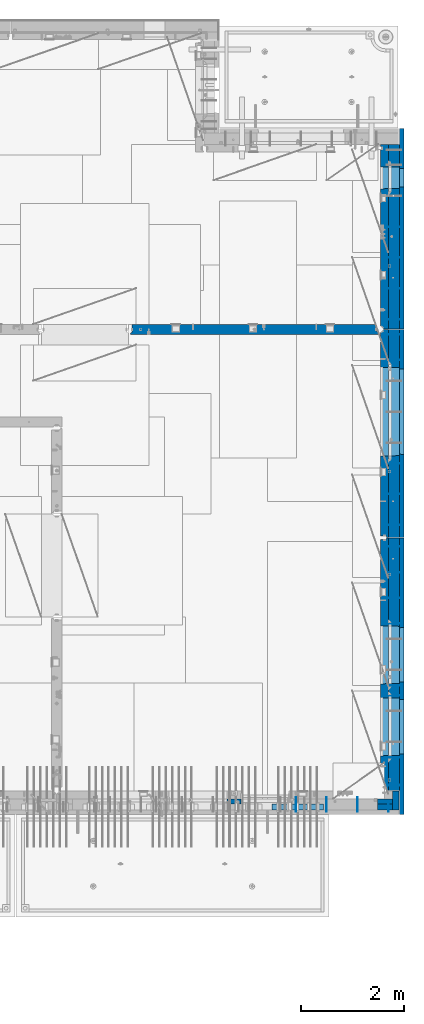
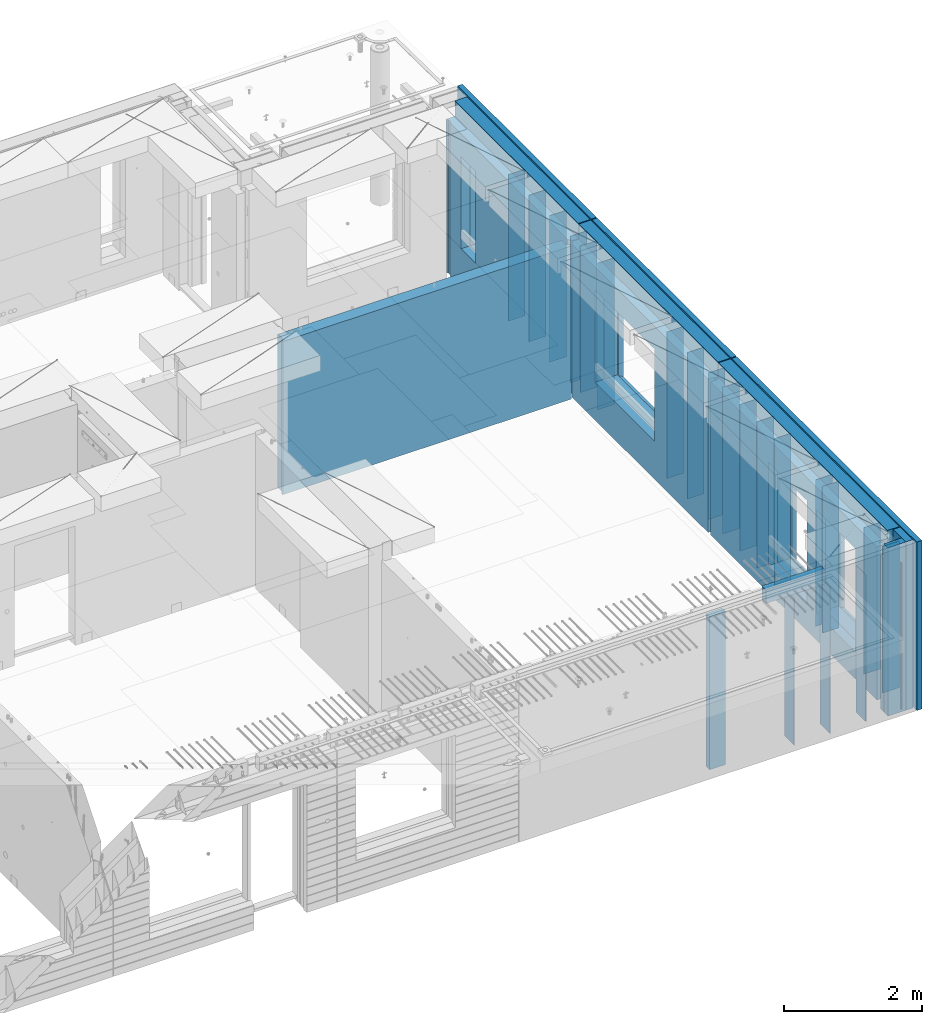
# One storey, part 230 of 334: 37 walls, 7 elements without a shape of their own.
"""IFC2X3 building model written with IfcOpenShell, lengths in millimetres."""

from ifc_helpers import new_model, si_unit, frame, origin_with_axes, place, context, subcontext, project, spatial, faceted_brep, material, type_object, element, aggregate, save


model = new_model("IFC2X3")

# Units and contexts
model_context = context("Model", 3, precision=1e-05, world=origin_with_axes())
body_context = subcontext(model_context, "Body", "Model", "MODEL_VIEW")
ifc_project = project(units=[si_unit("LENGTHUNIT", "METRE", prefix="MILLI"), si_unit("AREAUNIT", "SQUARE_METRE"), si_unit("VOLUMEUNIT", "CUBIC_METRE"), si_unit("MASSUNIT", "GRAM", prefix="KILO"), si_unit("TIMEUNIT", "SECOND"), si_unit("PLANEANGLEUNIT", "RADIAN"), si_unit("SOLIDANGLEUNIT", "STERADIAN"), si_unit("THERMODYNAMICTEMPERATUREUNIT", "DEGREE_CELSIUS"), si_unit("LUMINOUSINTENSITYUNIT", "LUMEN")], contexts=[model_context])

# Site, building, storey
site_placement = place(None, origin_with_axes())
site = spatial("IfcSite", under=ifc_project, at=site_placement, CompositionType="ELEMENT")
building_placement = place(site_placement, origin_with_axes())
building = spatial("IfcBuilding", under=site, at=building_placement, CompositionType="ELEMENT")
storey_placement = place(building_placement, origin_with_axes())
storey = spatial("IfcBuildingStorey", under=building, at=storey_placement, Name="3", CompositionType="ELEMENT", Elevation=0.0)

# Assembly, walls
assembly_1_placement = place(storey_placement, origin_with_axes())
assembly_1 = element("IfcElementAssembly", 1, at=assembly_1_placement, inside=storey, AssemblyPlace="NOTDEFINED", PredefinedType="REINFORCEMENT_UNIT")
ifc_material_1 = material(Name="Undefined")
wall_type_1 = type_object("IfcWallType", PredefinedType="NOTDEFINED")
wall_1_placement = place(assembly_1_placement, frame((35060.0, 7780.0, 89115.0), z_axis=(0.0, 0.0, 1.0), x_axis=(0.0, -1.0, 0.0)))
wall_1 = element("IfcWall", 2, at=wall_1_placement, type_object=wall_type_1, material=ifc_material_1, Name="(PD)", context=body_context, shape_type="Brep", body=[
    faceted_brep([(0.0, 5.0, -1300.0), (0.0, 5.0, 1300.0), (180.0, 5.0, 1300.0), (180.0, 5.0, -1300.0), (0.0, -5.0, 1300.0), (180.0, -5.0, 1300.0), (0.0, -5.0, -1300.0), (180.0, -5.0, -1300.0)], [[[0, 1, 2, 3]], [[1, 4, 5, 2]], [[4, 6, 7, 5]], [[6, 0, 3, 7]], [[5, 7, 3, 2]], [[6, 4, 1, 0]]]),
])
wall_2_placement = place(assembly_1_placement, frame((34460.0, 7880.0, 89115.0), z_axis=(0.0, 0.0, 1.0), x_axis=(0.0, -1.0, 0.0)))
wall_2 = element("IfcWall", 3, at=wall_2_placement, type_object=wall_type_1, material=ifc_material_1, Name="(PD)", context=body_context, shape_type="Brep", body=[
    faceted_brep([(0.0, 5.0, -1300.0), (0.0, 5.0, 1300.0), (280.0, 5.0, 1300.0), (280.0, 5.0, -1300.0), (0.0, -5.0, 1300.0), (280.0, -5.0, 1300.0), (0.0, -5.0, -1300.0), (280.0, -5.0, -1300.0)], [[[0, 1, 2, 3]], [[1, 4, 5, 2]], [[4, 6, 7, 5]], [[6, 0, 3, 7]], [[5, 7, 3, 2]], [[6, 4, 1, 0]]]),
])
wall_3_placement = place(assembly_1_placement, frame((33860.0, 7880.0, 89115.0), z_axis=(0.0, 0.0, 1.0), x_axis=(0.0, -1.0, 0.0)))
wall_3 = element("IfcWall", 4, at=wall_3_placement, type_object=wall_type_1, material=ifc_material_1, Name="(PD)", context=body_context, shape_type="Brep", body=[
    faceted_brep([(0.0, 5.0, -1300.0), (0.0, 5.0, 1300.0), (280.0, 5.0, 1300.0), (280.0, 5.0, -1300.0), (0.0, -5.0, 1300.0), (280.0, -5.0, 1300.0), (0.0, -5.0, -1300.0), (280.0, -5.0, -1300.0)], [[[0, 1, 2, 3]], [[1, 4, 5, 2]], [[4, 6, 7, 5]], [[6, 0, 3, 7]], [[5, 7, 3, 2]], [[6, 4, 1, 0]]]),
])

assembly_2_placement = place(storey_placement, origin_with_axes())
assembly_2 = element("IfcElementAssembly", 5, at=assembly_2_placement, inside=storey, AssemblyPlace="NOTDEFINED", PredefinedType="REINFORCEMENT_UNIT")
wall_4_placement = place(assembly_2_placement, frame((35030.0, 12755.0002861023, 89115.0), z_axis=(0.0, 0.0, 1.0), x_axis=(1.0, 0.0, 0.0)))
wall_4 = element("IfcWall", 6, at=wall_4_placement, type_object=wall_type_1, material=ifc_material_1, Name="(PD)", context=body_context, shape_type="Brep", body=[
    faceted_brep([(0.0, 5.0, -1300.0), (0.0, 5.0, 1300.0), (280.0, 5.0, 1300.0), (280.0, 5.0, -1300.0), (0.0, -5.0, 1300.0), (280.0, -5.0, 1300.0), (0.0, -5.0, -1300.0), (280.0, -5.0, -1300.0)], [[[0, 1, 2, 3]], [[1, 4, 5, 2]], [[4, 6, 7, 5]], [[6, 0, 3, 7]], [[5, 7, 3, 2]], [[6, 4, 1, 0]]]),
])
wall_5_placement = place(assembly_2_placement, frame((35030.0, 12255.0002861023, 89115.0), z_axis=(0.0, 0.0, 1.0), x_axis=(1.0, 0.0, 0.0)))
wall_5 = element("IfcWall", 7, at=wall_5_placement, type_object=wall_type_1, material=ifc_material_1, Name="(PD)", context=body_context, shape_type="Brep", body=[
    faceted_brep([(0.0, 5.0, -1300.0), (0.0, 5.0, 1300.0), (280.0, 5.0, 1300.0), (280.0, 5.0, -1300.0), (0.0, -5.0, 1300.0), (280.0, -5.0, 1300.0), (0.0, -5.0, -1300.0), (280.0, -5.0, -1300.0)], [[[0, 1, 2, 3]], [[1, 4, 5, 2]], [[4, 6, 7, 5]], [[6, 0, 3, 7]], [[5, 7, 3, 2]], [[6, 4, 1, 0]]]),
])
wall_6_placement = place(assembly_2_placement, frame((35030.0, 11755.0002861023, 89115.0), z_axis=(0.0, 0.0, 1.0), x_axis=(1.0, 0.0, 0.0)))
wall_6 = element("IfcWall", 8, at=wall_6_placement, type_object=wall_type_1, material=ifc_material_1, Name="(PD)", context=body_context, shape_type="Brep", body=[
    faceted_brep([(0.0, 5.0, -1300.0), (0.0, 5.0, 1300.0), (280.0, 5.0, 1300.0), (280.0, 5.0, -1300.0), (0.0, -5.0, 1300.0), (280.0, -5.0, 1300.0), (0.0, -5.0, -1300.0), (280.0, -5.0, -1300.0)], [[[0, 1, 2, 3]], [[1, 4, 5, 2]], [[4, 6, 7, 5]], [[6, 0, 3, 7]], [[5, 7, 3, 2]], [[6, 4, 1, 0]]]),
])
wall_7_placement = place(assembly_2_placement, frame((35030.0, 11255.0002861023, 89115.0), z_axis=(0.0, 0.0, 1.0), x_axis=(1.0, 0.0, 0.0)))
wall_7 = element("IfcWall", 9, at=wall_7_placement, type_object=wall_type_1, material=ifc_material_1, Name="(PD)", context=body_context, shape_type="Brep", body=[
    faceted_brep([(0.0, 5.0, -1300.0), (0.0, 5.0, 1300.0), (280.0, 5.0, 1300.0), (280.0, 5.0, -1300.0), (0.0, -5.0, 1300.0), (280.0, -5.0, 1300.0), (0.0, -5.0, -1300.0), (280.0, -5.0, -1300.0)], [[[0, 1, 2, 3]], [[1, 4, 5, 2]], [[4, 6, 7, 5]], [[6, 0, 3, 7]], [[5, 7, 3, 2]], [[6, 4, 1, 0]]]),
])
wall_8_placement = place(assembly_2_placement, frame((35030.0, 8105.0, 89115.0), z_axis=(0.0, 0.0, 1.0), x_axis=(1.0, 0.0, 0.0)))
wall_8 = element("IfcWall", 10, at=wall_8_placement, type_object=wall_type_1, material=ifc_material_1, Name="(PD)", context=body_context, shape_type="Brep", body=[
    faceted_brep([(0.0, 5.0, -1300.0), (0.0, 5.0, 1300.0), (280.0, 5.0, 1300.0), (280.0, 5.0, -1300.0), (0.0, -5.0, 1300.0), (280.0, -5.0, 1300.0), (0.0, -5.0, -1300.0), (280.0, -5.0, -1300.0)], [[[0, 1, 2, 3]], [[1, 4, 5, 2]], [[4, 6, 7, 5]], [[6, 0, 3, 7]], [[5, 7, 3, 2]], [[6, 4, 1, 0]]]),
])
wall_9_placement = place(assembly_2_placement, frame((35030.0, 8115.0, 89115.0), z_axis=(0.0, 0.0, 1.0), x_axis=(1.0, 0.0, 0.0)))
wall_9 = element("IfcWall", 11, at=wall_9_placement, type_object=wall_type_1, material=ifc_material_1, Name="(PD)", context=body_context, shape_type="Brep", body=[
    faceted_brep([(0.0, 5.0, -1300.0), (0.0, 5.0, 1300.0), (280.0, 5.0, 1300.0), (280.0, 5.0, -1300.0), (0.0, -5.0, 1300.0), (280.0, -5.0, 1300.0), (0.0, -5.0, -1300.0), (280.0, -5.0, -1300.0)], [[[0, 1, 2, 3]], [[1, 4, 5, 2]], [[4, 6, 7, 5]], [[6, 0, 3, 7]], [[5, 7, 3, 2]], [[6, 4, 1, 0]]]),
])
wall_10_placement = place(assembly_2_placement, frame((35030.0, 9855.00028610229, 89115.0), z_axis=(0.0, 0.0, 1.0), x_axis=(1.0, 0.0, 0.0)))
wall_10 = element("IfcWall", 12, at=wall_10_placement, type_object=wall_type_1, material=ifc_material_1, Name="(PD)", context=body_context, shape_type="Brep", body=[
    faceted_brep([(0.0, 5.0, -1300.0), (0.0, 5.0, 1300.0), (280.0, 5.0, 1300.0), (280.0, 5.0, -1300.0), (0.0, -5.0, 1300.0), (280.0, -5.0, 1300.0), (0.0, -5.0, -1300.0), (280.0, -5.0, -1300.0)], [[[0, 1, 2, 3]], [[1, 4, 5, 2]], [[4, 6, 7, 5]], [[6, 0, 3, 7]], [[5, 7, 3, 2]], [[6, 4, 1, 0]]]),
])
wall_11_placement = place(assembly_2_placement, frame((35030.0, 10055.0002861023, 89115.0), z_axis=(0.0, 0.0, 1.0), x_axis=(1.0, 0.0, 0.0)))
wall_11 = element("IfcWall", 13, at=wall_11_placement, type_object=wall_type_1, material=ifc_material_1, Name="(PD)", context=body_context, shape_type="Brep", body=[
    faceted_brep([(0.0, 5.0, -1300.0), (0.0, 5.0, 1300.0), (280.0, 5.0, 1300.0), (280.0, 5.0, -1300.0), (0.0, -5.0, 1300.0), (280.0, -5.0, 1300.0), (0.0, -5.0, -1300.0), (280.0, -5.0, -1300.0)], [[[0, 1, 2, 3]], [[1, 4, 5, 2]], [[4, 6, 7, 5]], [[6, 0, 3, 7]], [[5, 7, 3, 2]], [[6, 4, 1, 0]]]),
])

assembly_3_placement = place(storey_placement, origin_with_axes())
assembly_3 = element("IfcElementAssembly", 14, at=assembly_3_placement, inside=storey, AssemblyPlace="NOTDEFINED", PredefinedType="REINFORCEMENT_UNIT")
wall_12_placement = place(assembly_3_placement, frame((35030.0, 13175.0002861023, 89115.0), z_axis=(0.0, 0.0, 1.0), x_axis=(1.0, 0.0, 0.0)))
wall_12 = element("IfcWall", 15, at=wall_12_placement, type_object=wall_type_1, material=ifc_material_1, Name="(PD)", context=body_context, shape_type="Brep", body=[
    faceted_brep([(0.0, 5.0, -1300.0), (0.0, 5.0, 1300.0), (280.0, 5.0, 1300.0), (280.0, 5.0, -1300.0), (0.0, -5.0, 1300.0), (280.0, -5.0, 1300.0), (0.0, -5.0, -1300.0), (280.0, -5.0, -1300.0)], [[[0, 1, 2, 3]], [[1, 4, 5, 2]], [[4, 6, 7, 5]], [[6, 0, 3, 7]], [[5, 7, 3, 2]], [[6, 4, 1, 0]]]),
])
wall_13_placement = place(assembly_3_placement, frame((35030.0, 13775.0002861023, 89115.0), z_axis=(0.0, 0.0, 1.0), x_axis=(1.0, 0.0, 0.0)))
wall_13 = element("IfcWall", 16, at=wall_13_placement, type_object=wall_type_1, material=ifc_material_1, Name="(PD)", context=body_context, shape_type="Brep", body=[
    faceted_brep([(0.0, 5.0, -1300.0), (0.0, 5.0, 1300.0), (280.0, 5.0, 1300.0), (280.0, 5.0, -1300.0), (0.0, -5.0, 1300.0), (280.0, -5.0, 1300.0), (0.0, -5.0, -1300.0), (280.0, -5.0, -1300.0)], [[[0, 1, 2, 3]], [[1, 4, 5, 2]], [[4, 6, 7, 5]], [[6, 0, 3, 7]], [[5, 7, 3, 2]], [[6, 4, 1, 0]]]),
])
wall_14_placement = place(assembly_3_placement, frame((35030.0, 16885.0002861023, 89115.0), z_axis=(0.0, 0.0, 1.0), x_axis=(1.0, 0.0, 0.0)))
wall_14 = element("IfcWall", 17, at=wall_14_placement, type_object=wall_type_1, material=ifc_material_1, Name="(PD)", context=body_context, shape_type="Brep", body=[
    faceted_brep([(0.0, 5.0, -1300.0), (0.0, 5.0, 1300.0), (280.0, 5.0, 1300.0), (280.0, 5.0, -1300.0), (0.0, -5.0, 1300.0), (280.0, -5.0, 1300.0), (0.0, -5.0, -1300.0), (280.0, -5.0, -1300.0)], [[[0, 1, 2, 3]], [[1, 4, 5, 2]], [[4, 6, 7, 5]], [[6, 0, 3, 7]], [[5, 7, 3, 2]], [[6, 4, 1, 0]]]),
])
wall_15_placement = place(assembly_3_placement, frame((35030.0, 16385.0002861023, 89115.0), z_axis=(0.0, 0.0, 1.0), x_axis=(1.0, 0.0, 0.0)))
wall_15 = element("IfcWall", 18, at=wall_15_placement, type_object=wall_type_1, material=ifc_material_1, Name="(PD)", context=body_context, shape_type="Brep", body=[
    faceted_brep([(0.0, 5.0, -1300.0), (0.0, 5.0, 1300.0), (280.0, 5.0, 1300.0), (280.0, 5.0, -1300.0), (0.0, -5.0, 1300.0), (280.0, -5.0, 1300.0), (0.0, -5.0, -1300.0), (280.0, -5.0, -1300.0)], [[[0, 1, 2, 3]], [[1, 4, 5, 2]], [[4, 6, 7, 5]], [[6, 0, 3, 7]], [[5, 7, 3, 2]], [[6, 4, 1, 0]]]),
])

assembly_4_placement = place(storey_placement, origin_with_axes())
assembly_4 = element("IfcElementAssembly", 19, at=assembly_4_placement, inside=storey, AssemblyPlace="NOTDEFINED", PredefinedType="REINFORCEMENT_UNIT")
wall_16_placement = place(assembly_4_placement, frame((35030.0, 17175.0002441406, 89115.0), z_axis=(0.0, 0.0, 1.0), x_axis=(1.0, 0.0, 0.0)))
wall_16 = element("IfcWall", 20, at=wall_16_placement, type_object=wall_type_1, material=ifc_material_1, Name="(PD)", context=body_context, shape_type="Brep", body=[
    faceted_brep([(0.0, 5.0, -1300.0), (0.0, 5.0, 1300.0), (280.0, 5.0, 1300.0), (280.0, 5.0, -1300.0), (0.0, -5.0, 1300.0), (280.0, -5.0, 1300.0), (0.0, -5.0, -1300.0), (280.0, -5.0, -1300.0)], [[[0, 1, 2, 3]], [[1, 4, 5, 2]], [[4, 6, 7, 5]], [[6, 0, 3, 7]], [[5, 7, 3, 2]], [[6, 4, 1, 0]]]),
])
wall_17_placement = place(assembly_4_placement, frame((35030.0, 17775.0002441406, 89115.0), z_axis=(0.0, 0.0, 1.0), x_axis=(1.0, 0.0, 0.0)))
wall_17 = element("IfcWall", 21, at=wall_17_placement, type_object=wall_type_1, material=ifc_material_1, Name="(PD)", context=body_context, shape_type="Brep", body=[
    faceted_brep([(0.0, 5.0, -1300.0), (0.0, 5.0, 1300.0), (280.0, 5.0, 1300.0), (280.0, 5.0, -1300.0), (0.0, -5.0, 1300.0), (280.0, -5.0, 1300.0), (0.0, -5.0, -1300.0), (280.0, -5.0, -1300.0)], [[[0, 1, 2, 3]], [[1, 4, 5, 2]], [[4, 6, 7, 5]], [[6, 0, 3, 7]], [[5, 7, 3, 2]], [[6, 4, 1, 0]]]),
])
wall_18_placement = place(assembly_4_placement, frame((35030.0, 18375.0002441406, 89115.0), z_axis=(0.0, 0.0, 1.0), x_axis=(1.0, 0.0, 0.0)))
wall_18 = element("IfcWall", 22, at=wall_18_placement, type_object=wall_type_1, material=ifc_material_1, Name="(PD)", context=body_context, shape_type="Brep", body=[
    faceted_brep([(0.0, 5.0, -1300.0), (0.0, 5.0, 1300.0), (280.0, 5.0, 1300.0), (280.0, 5.0, -1300.0), (0.0, -5.0, 1300.0), (280.0, -5.0, 1300.0), (0.0, -5.0, -1300.0), (280.0, -5.0, -1300.0)], [[[0, 1, 2, 3]], [[1, 4, 5, 2]], [[4, 6, 7, 5]], [[6, 0, 3, 7]], [[5, 7, 3, 2]], [[6, 4, 1, 0]]]),
])
wall_19_placement = place(assembly_4_placement, frame((35030.0, 18975.0002441406, 89115.0), z_axis=(0.0, 0.0, 1.0), x_axis=(1.0, 0.0, 0.0)))
wall_19 = element("IfcWall", 23, at=wall_19_placement, type_object=wall_type_1, material=ifc_material_1, Name="(PD)", context=body_context, shape_type="Brep", body=[
    faceted_brep([(0.0, 5.0, -1300.0), (0.0, 5.0, 1300.0), (280.0, 5.0, 1300.0), (280.0, 5.0, -1300.0), (0.0, -5.0, 1300.0), (280.0, -5.0, 1300.0), (0.0, -5.0, -1300.0), (280.0, -5.0, -1300.0)], [[[0, 1, 2, 3]], [[1, 4, 5, 2]], [[4, 6, 7, 5]], [[6, 0, 3, 7]], [[5, 7, 3, 2]], [[6, 4, 1, 0]]]),
])

# Wall
wall_20_placement = place(assembly_3_placement, frame((35030.0, 14375.0002861023, 89115.0), z_axis=(0.0, 0.0, 1.0), x_axis=(1.0, 0.0, 0.0)))
wall_20 = element("IfcWall", 24, at=wall_20_placement, type_object=wall_type_1, material=ifc_material_1, Name="(PD)", context=body_context, shape_type="Brep", body=[
    faceted_brep([(0.0, 5.0, -1300.0), (0.0, 5.0, 1300.0), (280.0, 5.0, 1300.0), (280.0, 5.0, -1300.0), (0.0, -5.0, 1300.0), (280.0, -5.0, 1300.0), (0.0, -5.0, -1300.0), (280.0, -5.0, -1300.0)], [[[0, 1, 2, 3]], [[1, 4, 5, 2]], [[4, 6, 7, 5]], [[6, 0, 3, 7]], [[5, 7, 3, 2]], [[6, 4, 1, 0]]]),
])

wall_21_placement = place(assembly_1_placement, frame((33260.0, 7880.0, 89115.0), z_axis=(0.0, 0.0, 1.0), x_axis=(0.0, -1.0, 0.0)))
wall_21 = element("IfcWall", 25, at=wall_21_placement, type_object=wall_type_1, material=ifc_material_1, Name="(PD)", context=body_context, shape_type="Brep", body=[
    faceted_brep([(0.0, 5.0, -1300.0), (0.0, 5.0, 1300.0), (280.0, 5.0, 1300.0), (280.0, 5.0, -1300.0), (0.0, -5.0, 1300.0), (280.0, -5.0, 1300.0), (0.0, -5.0, -1300.0), (280.0, -5.0, -1300.0)], [[[0, 1, 2, 3]], [[1, 4, 5, 2]], [[4, 6, 7, 5]], [[6, 0, 3, 7]], [[5, 7, 3, 2]], [[6, 4, 1, 0]]]),
])

wall_22_placement = place(assembly_2_placement, frame((35030.0, 8655.0, 89115.0), z_axis=(0.0, 0.0, 1.0), x_axis=(1.0, 0.0, 0.0)))
wall_22 = element("IfcWall", 26, at=wall_22_placement, type_object=wall_type_1, material=ifc_material_1, Name="(PD)", context=body_context, shape_type="Brep", body=[
    faceted_brep([(0.0, 5.0, -1300.0), (0.0, 5.0, 1300.0), (280.0, 5.0, 1300.0), (280.0, 5.0, -1300.0), (0.0, -5.0, 1300.0), (280.0, -5.0, 1300.0), (0.0, -5.0, -1300.0), (280.0, -5.0, -1300.0)], [[[0, 1, 2, 3]], [[1, 4, 5, 2]], [[4, 6, 7, 5]], [[6, 0, 3, 7]], [[5, 7, 3, 2]], [[6, 4, 1, 0]]]),
])

# Assembly, wall
assembly_5_placement = place(storey_placement, origin_with_axes())
assembly_5 = element("IfcElementAssembly", 27, at=assembly_5_placement, inside=storey, AssemblyPlace="NOTDEFINED", PredefinedType="REINFORCEMENT_UNIT")
ifc_material_2 = material(Name="CONCRETE/C25/30")
wall_type_2 = type_object("IfcWallType", PredefinedType="NOTDEFINED")
wall_23_placement = place(assembly_5_placement, frame((30040.0, 16980.0002441406, 89112.5), z_axis=(0.0, 0.0, 1.0), x_axis=(1.0, 0.0, 0.0)))
wall_23 = element("IfcWall", 28, at=wall_23_placement, type_object=wall_type_2, material=ifc_material_2, context=body_context, shape_type="Brep", body=[
    faceted_brep([(4785.0, 100.0, 1357.5), (4785.0, -30.0, 1357.5), (4785.0, -30.0, -1357.5), (4785.0, 100.0, -1357.5), (4840.0, -60.0, 1357.5), (4840.0, -60.0, -1357.5), (30.0003214753524, 100.0, 1357.5), (30.0003214753524, 100.0, -1357.5), (30.0003214753524, -57.0, -1357.5), (30.0003214753524, -57.0, 1357.5), (0.0, -70.0001393059865, -1357.5), (0.0, -70.0001393059865, 1357.5), (0.0, -100.0, -1357.5), (0.0, -100.0, 1357.5), (4840.0, -100.0, -1357.5), (4840.0, -100.0, 1357.5)], [[[0, 1, 2, 3]], [[4, 5, 2, 1]], [[6, 7, 8, 9]], [[9, 8, 10, 11]], [[12, 13, 11, 10]], [[13, 12, 14, 15]], [[0, 6, 9, 11, 13, 15, 4, 1]], [[7, 6, 0, 3]], [[14, 12, 10, 8, 7, 3, 2, 5]], [[15, 14, 5, 4]]]),
])
aggregate(assembly_5, [wall_23])

# Assemblies, wall
assembly_6_placement = place(storey_placement, origin_with_axes())
assembly_6 = element("IfcElementAssembly", 29, at=assembly_6_placement, inside=storey, AssemblyPlace="NOTDEFINED", PredefinedType="REINFORCEMENT_UNIT")
assembly_7_placement = place(assembly_6_placement, origin_with_axes())
assembly_7 = element("IfcElementAssembly", 30, at=assembly_7_placement, Name="Steel Assembly", AssemblyPlace="NOTDEFINED", PredefinedType="NOTDEFINED")
aggregate(assembly_6, [assembly_7])
ifc_material_3 = material()
wall_type_3 = type_object("IfcWallType", PredefinedType="NOTDEFINED")
wall_24_placement = place(assembly_7_placement, frame((32799.9998568133, 7690.00021946163, 90590.0), z_axis=(0.0, 0.0, 1.0), x_axis=(1.0, 0.0, 0.0)))
wall_24 = element("IfcWall", 31, at=wall_24_placement, type_object=wall_type_3, material=ifc_material_3, context=body_context, shape_type="Brep", body=[
    faceted_brep([(0.0, 60.0, -120.0), (0.0, 60.0, 120.0), (1000.0, 60.0, 120.0), (1000.0, 60.0, -120.0), (0.0, -60.0, 120.0), (1000.0, -60.0, 120.0), (0.0, -60.0, -120.0), (1000.0, -60.0, -120.0)], [[[0, 1, 2, 3]], [[1, 4, 5, 2]], [[4, 6, 7, 5]], [[6, 0, 3, 7]], [[5, 7, 3, 2]], [[6, 4, 1, 0]]]),
])
aggregate(assembly_7, [wall_24])

# Wall
ifc_material_4 = material(Name="COS5gt")
wall_type_4 = type_object("IfcWallType", PredefinedType="NOTDEFINED")
wall_25_placement = place(assembly_2_placement, frame((35170.0, 12920.0002861023, 89247.5), z_axis=(0.0, 0.0, 1.0), x_axis=(0.0, -1.0, 0.0)))
wall_25 = element("IfcWall", 32, at=wall_25_placement, type_object=wall_type_4, material=ifc_material_4, context=body_context, shape_type="Brep", body=[
    faceted_brep([(0.0, 90.0, 1492.5), (4905.00028610229, 90.0, 1492.5), (4905.00028610229, 90.0, 1442.5), (-0.25, 90.0, 1442.5), (0.0, -110.0, 1492.5), (4905.00028610229, -110.0, 1492.5), (4905.00028610229, 110.0, 1442.5), (4905.00028610229, -110.0, -1492.5), (4905.00028610229, 90.0, -1492.5), (4905.00028610229, 90.0, -1442.5), (4905.00028610229, 110.0, -1442.5), (-0.25, 110.0, 1442.5), (0.0, 90.0, -1492.5), (0.0, -110.0, -1492.5), (-0.25, 110.0, -1442.5), (-0.25, 90.0, -1442.5), (3115.00024333302, 110.0, -1007.5), (3145.00024333302, 110.0, -1007.5), (4195.00024333302, 110.0, -1007.5), (4225.00024333302, 110.0, -1007.5), (4225.00024333302, 110.0, -1002.5), (4225.00024333302, 110.0, 807.5), (3115.00024333302, 110.0, 807.5), (3115.00024333302, 110.0, -1002.5), (1715.00062480275, 110.0, -1007.5), (1745.00062480275, 110.0, -1007.5), (2795.00062480275, 110.0, -1007.5), (2825.00062480275, 110.0, -1007.5), (2825.00062480275, 110.0, -1002.5), (2825.00062480275, 110.0, 807.5), (1715.00062480275, 110.0, 807.5), (1715.00062480275, 110.0, -1002.5), (4230.94618927897, -110.0, -1013.44594594595), (4230.94618927897, -110.0, 813.445945945947), (3109.05429738708, -110.0, -1013.44594594595), (3109.05429738708, -110.0, 813.445945945947), (2830.9465707487, -110.0, -1013.44594594595), (1709.0546788568, -110.0, -1013.44594594595), (1709.0546788568, -110.0, 813.445945945947), (2830.9465707487, -110.0, 813.445945945947)], [[[0, 1, 2, 3]], [[4, 5, 1, 0]], [[6, 2, 1, 5, 7, 8, 9, 10]], [[11, 3, 2, 6]], [[12, 13, 4, 0, 3, 11, 14, 15]], [[7, 13, 12, 8]], [[15, 9, 8, 12]], [[14, 10, 9, 15]], [[11, 6, 10, 14], [16, 17, 18, 19, 20, 21, 22, 23], [24, 25, 26, 27, 28, 29, 30, 31]], [[20, 19, 32, 33, 21]], [[18, 17, 16, 34, 32, 19]], [[23, 22, 35, 34, 16]], [[21, 33, 35, 22]], [[4, 13, 7, 5], [32, 34, 35, 33], [36, 37, 38, 39]], [[26, 25, 24, 37, 36, 27]], [[31, 30, 38, 37, 24]], [[29, 39, 38, 30]], [[28, 27, 36, 39, 29]]]),
])

wall_26_placement = place(assembly_3_placement, frame((35170.0, 16980.0002861023, 89247.5), z_axis=(0.0, 0.0, 1.0), x_axis=(0.0, -1.0, 0.0)))
wall_26 = element("IfcWall", 33, at=wall_26_placement, type_object=wall_type_4, material=ifc_material_4, context=body_context, shape_type="Brep", body=[
    faceted_brep([(1409.0, 90.0, -1492.5), (1409.0, 90.0, -1442.5), (4045.0, 90.0, -1442.5), (4045.0, 90.0, -1492.5), (5.0, 110.0, -1492.5), (5.0, -110.0, -1492.5), (5.0, -110.0, 1492.5), (5.00004196166992, 90.0, 1492.5), (5.00004196166992, 90.0, 1442.5), (5.00004196166992, 110.0, 1442.5), (4045.0, -110.0, -1492.5), (4045.0, -110.0, 1492.5), (2460.94588410319, -110.0, -813.445945945947), (739.053992211293, -110.0, -813.445945945947), (739.053992211293, -110.0, 813.445945945947), (2460.94588410319, -110.0, 813.445945945947), (2454.99993815724, 110.0, 807.5), (744.99993815724, 110.0, 807.5), (2454.99993815724, 110.0, -802.5), (2454.99993815724, 110.0, -807.5), (2424.99993815724, 110.0, -807.5), (774.99993815724, 110.0, -807.5), (744.99993815724, 110.0, -807.5), (744.99993815724, 110.0, -802.5), (4045.0, 110.0, 1442.5), (4045.0, 110.0, -1442.5), (1409.0, 110.0, -1442.5), (1409.0, 110.0, -1492.5), (4045.0, 90.0, 1442.5), (4045.0, 90.0, 1492.5)], [[[0, 1, 2, 3]], [[4, 5, 6, 7, 8, 9]], [[6, 5, 10, 11], [12, 13, 14, 15]], [[16, 15, 14, 17]], [[18, 19, 12, 15, 16]], [[20, 21, 22, 13, 12, 19]], [[23, 17, 14, 13, 22]], [[4, 9, 24, 25, 26, 27], [22, 21, 20, 19, 18, 16, 17, 23]], [[3, 10, 5, 4, 27, 0]], [[26, 1, 0, 27]], [[25, 2, 1, 26]], [[24, 28, 29, 11, 10, 3, 2, 25]], [[9, 8, 28, 24]], [[7, 29, 28, 8]], [[6, 11, 29, 7]]]),
])

wall_27_placement = place(assembly_4_placement, frame((35170.0, 20575.0002441406, 89247.5), z_axis=(0.0, 0.0, 1.0), x_axis=(0.0, -1.0, 0.0)))
wall_27 = element("IfcWall", 34, at=wall_27_placement, type_object=wall_type_4, material=ifc_material_4, context=body_context, shape_type="Brep", body=[
    faceted_brep([(0.0, 90.0, 1492.5), (3585.0, 90.0, 1492.5), (3585.0, 90.0, 1442.5), (0.0, 90.0, 1442.5), (0.0, -110.0, 1492.5), (3585.0, -110.0, 1492.5), (3585.0, 110.0, 1442.5), (3585.0, -110.0, -1492.5), (3585.0, 90.0, -1492.5), (3585.0, 90.0, -1442.5), (3585.0, 110.0, -1442.5), (0.0, 110.0, 1442.5), (0.0, 90.0, -1492.5), (0.0, -110.0, -1492.5), (0.0, 110.0, -1442.5), (0.0, 90.0, -1442.5), (440.000277665298, 110.0, -807.5), (470.000277665298, 110.0, -807.5), (820.000277665298, 110.0, -807.5), (850.000277665298, 110.0, -807.5), (850.000277665298, 110.0, -802.5), (850.000277665298, 110.0, 807.5), (440.000277665298, 110.0, 807.5), (440.000277665298, 110.0, -802.5), (855.946223611245, -110.0, -813.445945945947), (855.946223611245, -110.0, 813.445945945947), (434.054331719351, -110.0, -813.445945945947), (434.054331719351, -110.0, 813.445945945947)], [[[0, 1, 2, 3]], [[4, 5, 1, 0]], [[6, 2, 1, 5, 7, 8, 9, 10]], [[11, 3, 2, 6]], [[12, 13, 4, 0, 3, 11, 14, 15]], [[7, 13, 12, 8]], [[15, 9, 8, 12]], [[14, 10, 9, 15]], [[11, 6, 10, 14], [16, 17, 18, 19, 20, 21, 22, 23]], [[20, 19, 24, 25, 21]], [[18, 17, 16, 26, 24, 19]], [[23, 22, 27, 26, 16]], [[21, 25, 27, 22]], [[4, 13, 7, 5], [24, 26, 27, 25]]]),
])

ifc_material_5 = material(Name="CONCRETE/C30/37")
wall_type_5 = type_object("IfcWallType", PredefinedType="NOTDEFINED")
wall_28_placement = place(assembly_2_placement, frame((35322.5, 12920.2502861023, 89247.5), z_axis=(0.0, 0.0, 1.0), x_axis=(0.0, -1.0, 0.0)))
wall_28 = element("IfcWall", 35, at=wall_28_placement, type_object=wall_type_5, material=ifc_material_5, context=body_context, shape_type="Brep", body=[
    faceted_brep([(0.0, 42.5, 1492.5), (0.0, -42.5, 1492.5), (5375.25028610229, -42.5, 1492.5), (5375.25028610229, 42.5, 1492.5), (0.0, -42.5, -1492.5), (0.0, 42.5, -1492.5), (5375.25028610229, 42.5, -1492.5), (5375.25028610229, -42.5, -1492.5), (4205.25024333302, 42.5, -1057.5), (4195.25024333302, -42.5, -1007.5), (4195.25024333302, -42.5, 782.5), (4195.25024333302, -42.5, 787.5), (4205.25024333302, 42.5, 782.5), (3135.25024333302, 42.5, -1057.5), (3145.25024333302, -42.5, -1007.5), (3135.25024333302, 42.5, 782.5), (3145.25024333302, -42.5, 787.5), (3145.25024333302, -42.5, 782.5), (3145.25024333302, 42.5, 782.5), (4195.25024333302, 42.5, 782.5), (2795.25062480275, -42.5, 782.5), (2795.25062480275, -42.5, -1007.5), (1745.25062480275, -42.5, -1007.5), (1745.25062480275, -42.5, 782.5), (1745.25062480275, -42.5, 787.5), (2795.25062480275, -42.5, 787.5), (1745.25062480275, 42.5, 782.5), (2795.25062480275, 42.5, 782.5), (2805.25062480275, 42.5, 782.5), (1735.25062480275, 42.5, 782.5), (2805.25062480275, 42.5, -1057.5), (1735.25062480275, 42.5, -1057.5)], [[[0, 1, 2, 3]], [[4, 5, 6, 7]], [[2, 7, 6, 3]], [[8, 9, 10, 11, 12]], [[13, 14, 9, 8]], [[15, 16, 17, 14, 13]], [[18, 19, 12, 11, 16, 15]], [[1, 4, 7, 2], [20, 21, 22, 23, 24, 25], [10, 9, 14, 17, 16, 11]], [[26, 27, 28, 25, 24, 29]], [[30, 21, 20, 25, 28]], [[31, 22, 21, 30]], [[29, 24, 23, 22, 31]], [[5, 0, 3, 6], [30, 28, 27, 26, 29, 31], [8, 12, 19, 18, 15, 13]], [[4, 1, 0, 5]]]),
])

wall_29_placement = place(assembly_3_placement, frame((35322.5, 16980.0002861023, 89247.5), z_axis=(0.0, 0.0, 1.0), x_axis=(0.0, -1.0, 0.0)))
wall_29 = element("IfcWall", 36, at=wall_29_placement, type_object=wall_type_5, material=ifc_material_5, context=body_context, shape_type="Brep", body=[
    faceted_brep([(5.00004196166992, 42.5, 1492.5), (5.00004196166992, -42.5, 1492.5), (4045.0, -42.5, 1492.5), (4045.0, 42.5, 1492.5), (5.00004196166992, -42.5, -1492.5), (5.00004196166992, 42.5, -1492.5), (4045.0, 42.5, -1492.5), (4045.0, -42.5, -1492.5), (2424.99993815724, -42.5, 782.5), (2424.99993815724, -42.5, 781.785034179688), (2424.99993815724, -42.5, -807.5), (774.99993815724, -42.5, -807.5), (774.99993815724, -42.5, 781.785034179688), (774.99993815724, -42.5, 782.5), (774.99993815724, -42.5, 787.5), (2424.99993815724, -42.5, 787.5), (774.99993815724, 42.5, 782.5), (2424.99993815724, 42.5, 782.5), (2434.99993815724, 42.5, 782.5), (764.99993815724, 42.5, 782.5), (2434.99993815724, 42.5, -857.5), (764.99993815724, 42.5, -857.5)], [[[0, 1, 2, 3]], [[4, 5, 6, 7]], [[2, 7, 6, 3]], [[1, 4, 7, 2], [8, 9, 10, 11, 12, 13, 14, 15]], [[16, 17, 18, 15, 14, 19]], [[20, 10, 9, 8, 15, 18]], [[21, 11, 10, 20]], [[19, 14, 13, 12, 11, 21]], [[5, 0, 3, 6], [20, 18, 17, 16, 19, 21]], [[4, 1, 0, 5]]]),
])

wall_30_placement = place(assembly_4_placement, frame((35322.5, 20432.0002441406, 89247.5), z_axis=(0.0, 0.0, 1.0), x_axis=(0.0, -1.0, 0.0)))
wall_30 = element("IfcWall", 37, at=wall_30_placement, type_object=wall_type_5, material=ifc_material_5, context=body_context, shape_type="Brep", body=[
    faceted_brep([(-453.0, -42.5, -1492.5), (-453.0, -42.5, 1492.5), (-453.0, 42.5, 1492.5), (-453.0, 42.5, -1492.5), (3442.0, 42.5, -1492.5), (3442.0, -42.5, -1492.5), (3442.0, -42.5, 1492.5), (677.000277665298, -42.5, 782.5), (677.000277665298, -42.5, -807.5), (327.000277665298, -42.5, -807.5), (327.000277665298, -42.5, 782.5), (327.000277665298, -42.5, 787.5), (677.000277665298, -42.5, 787.5), (327.000277665298, 42.5, 782.5), (677.000277665298, 42.5, 782.5), (687.000277665298, 42.5, 782.5), (317.000277665298, 42.5, 782.5), (687.000277665298, 42.5, -857.5), (317.000277665298, 42.5, -857.5), (3442.0, 42.5, 1492.5)], [[[0, 1, 2, 3]], [[0, 3, 4, 5]], [[1, 0, 5, 6], [7, 8, 9, 10, 11, 12]], [[13, 14, 15, 12, 11, 16]], [[17, 8, 7, 12, 15]], [[18, 9, 8, 17]], [[16, 11, 10, 9, 18]], [[3, 2, 19, 4], [17, 15, 14, 13, 16, 18]], [[6, 5, 4, 19]], [[2, 1, 6, 19]]]),
])

wall_type_6 = type_object("IfcWallType", PredefinedType="NOTDEFINED")
wall_31_placement = place(assembly_2_placement, frame((34985.0, 12920.0002861023, 89112.5), z_axis=(0.0, 0.0, 1.0), x_axis=(0.0, -1.0, 0.0)))
wall_31 = element("IfcWall", 38, at=wall_31_placement, type_object=wall_type_6, material=ifc_material_2, context=body_context, shape_type="Brep", body=[
    faceted_brep([(4855.00028610229, -75.0, 1357.5), (4855.00028610229, -75.0, -1357.5), (4855.00028610229, 32.0000069488524, -1357.5), (4855.00028610229, 32.0000069488524, 1357.5), (4905.00028610229, 45.0000069488524, 1357.5), (4905.00028610229, 45.0000069488524, -1357.5), (29.9999989126591, 32.0000004547946, 1357.5), (29.9999989126591, 32.0000004547946, -1357.5), (30.0000016637459, -75.0, -1357.5), (30.0000016637459, -75.0, 1357.5), (0.0, 45.0, 1357.5), (0.0, 45.0, -1357.5), (0.0, 75.0, 1357.5), (0.0, 75.0, -1357.5), (4905.00028610229, 75.0, -1357.5), (4905.00028610229, 75.0, 1357.5), (4230.94618927897, 75.0, 948.445945945947), (4235.00024333302, -75.0, 952.5), (3105.00024333302, -75.0, 952.5), (3109.05429738708, 75.0, 948.445945945947), (4230.94618927897, 75.0, -878.445945945947), (4235.00024333302, -75.0, -882.5), (3109.05429738708, 75.0, -878.445945945947), (3105.00024333302, -75.0, -882.5), (2830.9465707487, 75.0, -878.445945945947), (2830.9465707487, 75.0, 948.445945945947), (1709.0546788568, 75.0, 948.445945945947), (1709.0546788568, 75.0, -878.445945945947), (2835.00062480275, -75.0, -882.5), (2835.00062480275, -75.0, 952.5), (1705.00062480275, -75.0, -882.5), (1705.00062480275, -75.0, 952.5)], [[[0, 1, 2, 3]], [[4, 3, 2, 5]], [[6, 7, 8, 9]], [[10, 11, 7, 6]], [[12, 13, 11, 10]], [[1, 8, 7, 11, 13, 14, 5, 2]], [[14, 15, 4, 5]], [[16, 17, 18, 19]], [[20, 21, 17, 16]], [[22, 23, 21, 20]], [[19, 18, 23, 22]], [[13, 12, 15, 14], [20, 16, 19, 22], [24, 25, 26, 27]], [[24, 28, 29, 25]], [[27, 30, 28, 24]], [[26, 31, 30, 27]], [[25, 29, 31, 26]], [[9, 8, 1, 0], [28, 30, 31, 29], [21, 23, 18, 17]], [[15, 12, 10, 6, 9, 0, 3, 4]]]),
])

aggregate(assembly_2, [wall_4, wall_5, wall_6, wall_7, wall_8, wall_9, wall_10, wall_11, wall_22, wall_28, wall_25, wall_31])

wall_32_placement = place(assembly_3_placement, frame((34985.0, 16980.0002861023, 89112.5), z_axis=(0.0, 0.0, 1.0), x_axis=(0.0, -1.0, 0.0)))
wall_32 = element("IfcWall", 39, at=wall_32_placement, type_object=wall_type_6, material=ifc_material_2, context=body_context, shape_type="Brep", body=[
    faceted_brep([(5.0, 75.0, -1357.5), (5.0, 75.0, 1357.5), (4045.0, 75.0, 1357.5), (4045.0, 75.0, -1357.5), (2460.94588410319, 75.0, -678.445945945947), (2460.94588410319, 75.0, 948.445945945947), (739.053992211293, 75.0, 948.445945945947), (739.053992211293, 75.0, -678.445945945947), (5.0, -15.0000022791291, -1357.5), (5.0, -15.0000022791291, 1357.5), (65.0, -75.0, 1357.5), (65.0, -75.0, -1357.5), (4015.0, -75.0, 1357.5), (4015.0, 32.0, 1357.5), (4045.0, 45.0, 1357.5), (4045.0, 45.0, -1357.5), (4015.0, -75.0, -1357.5), (4015.0, 32.0, -1357.5), (2464.99993815724, -75.0, -682.5), (734.99993815724, -75.0, -682.5), (734.99993815724, -75.0, 952.5), (2464.99993815724, -75.0, 952.5)], [[[0, 1, 2, 3], [4, 5, 6, 7]], [[1, 0, 8, 9]], [[10, 9, 8, 11]], [[2, 1, 9, 10, 12, 13, 14]], [[3, 2, 14, 15]], [[16, 11, 8, 0, 3, 15, 17]], [[14, 13, 17, 15]], [[12, 16, 17, 13]], [[10, 11, 16, 12], [18, 19, 20, 21]], [[6, 20, 19, 7]], [[5, 21, 20, 6]], [[4, 18, 21, 5]], [[7, 19, 18, 4]]]),
])

aggregate(assembly_3, [wall_12, wall_13, wall_14, wall_15, wall_20, wall_32, wall_26, wall_29])

wall_33_placement = place(assembly_4_placement, frame((34985.0, 20575.0002441406, 89112.5), z_axis=(0.0, 0.0, 1.0), x_axis=(0.0, -1.0, 0.0)))
wall_33 = element("IfcWall", 40, at=wall_33_placement, type_object=wall_type_6, material=ifc_material_2, context=body_context, shape_type="Brep", body=[
    faceted_brep([(0.0, 75.0, -1357.5), (0.0, 75.0, 1357.5), (3585.0, 75.0, 1357.5), (3585.0, 75.0, -1357.5), (855.946223611245, 75.0, -678.445945945947), (855.946223611245, 75.0, 948.445945945947), (434.054331719351, 75.0, 948.445945945947), (434.054331719351, 75.0, -678.445945945947), (0.0, -75.0, -1357.5), (0.0, -75.0, 1357.5), (30.0050569130617, -75.0, -1357.5), (30.0050569130617, -75.0, 1357.5), (43.0050569130617, -55.0, -1357.5), (43.0050569130617, -55.0, 1357.5), (97.0050569130617, -55.0, -1357.5), (97.0050569130617, -55.0, 1357.5), (110.005056913062, -75.0, -1357.5), (110.005056913062, -75.0, 1357.5), (3525.0, -75.0, 1357.5), (3585.0, -15.0, 1357.5), (3585.0, -15.0, -1357.5), (3525.0, -75.0, -1357.5), (860.000277665298, -75.0, -682.5), (430.000277665298, -75.0, -682.5), (430.000277665298, -75.0, 952.5), (860.000277665298, -75.0, 952.5)], [[[0, 1, 2, 3], [4, 5, 6, 7]], [[8, 9, 1, 0]], [[9, 8, 10, 11]], [[11, 10, 12, 13]], [[13, 12, 14, 15]], [[15, 14, 16, 17]], [[2, 1, 9, 11, 13, 15, 17, 18, 19]], [[3, 2, 19, 20]], [[16, 14, 12, 10, 8, 0, 3, 20, 21]], [[19, 18, 21, 20]], [[17, 16, 21, 18], [22, 23, 24, 25]], [[6, 24, 23, 7]], [[5, 25, 24, 6]], [[4, 22, 25, 5]], [[7, 23, 22, 4]]]),
])

aggregate(assembly_4, [wall_16, wall_17, wall_18, wall_19, wall_30, wall_27, wall_33])

ifc_material_6 = material(Name="CONCRETE/C35/45")
wall_type_7 = type_object("IfcWallType", PredefinedType="NOTDEFINED")
wall_34_placement = place(assembly_1_placement, frame((35145.0000381475, 7800.0, 89112.5), z_axis=(0.0, 0.0, 1.0), x_axis=(-1.0, 3.00000001838171e-08, 0.0)))
wall_34 = element("IfcWall", 41, at=wall_34_placement, type_object=wall_type_7, material=ifc_material_6, context=body_context, shape_type="Brep", body=[
    faceted_brep([(0.0, 50.0, -1357.5), (0.0, 50.0, 1357.5), (300.001908754726, 50.0, 1357.5), (300.001908754726, 50.0, -1357.5), (0.0, -50.0, 1357.5), (300.001908754726, -50.0, 1357.5), (0.0, -50.0, -1357.5), (300.001908754726, -50.0, -1357.5)], [[[0, 1, 2, 3]], [[1, 4, 5, 2]], [[4, 6, 7, 5]], [[6, 0, 3, 7]], [[5, 7, 3, 2]], [[6, 4, 1, 0]]]),
])

wall_35_placement = place(assembly_1_placement, frame((32195.0000381475, 7800.0, 89112.5), z_axis=(0.0, 0.0, 1.0), x_axis=(-1.0, 3.00000001838171e-08, 0.0)))
wall_35 = element("IfcWall", 42, at=wall_35_placement, type_object=wall_type_7, material=ifc_material_6, context=body_context, shape_type="Brep", body=[
    faceted_brep([(0.0, 50.0, -1357.5), (0.0, 50.0, 1357.5), (270.001908754726, 50.0, 1357.5), (270.001908754726, 50.0, -1357.5), (0.0, -50.0, 1357.5), (270.001908754726, -50.0, 1357.5), (0.0, -50.0, -1357.5), (270.001908754726, -50.0, -1357.5)], [[[0, 1, 2, 3]], [[1, 4, 5, 2]], [[4, 6, 7, 5]], [[6, 0, 3, 7]], [[5, 7, 3, 2]], [[6, 4, 1, 0]]]),
])

ifc_material_7 = material(Name="SPU")
wall_type_8 = type_object("IfcWallType", PredefinedType="NOTDEFINED")
wall_36_placement = place(assembly_1_placement, frame((35145.0000381475, 7690.0, 89247.5), z_axis=(0.0, 0.0, 1.0), x_axis=(-1.0, 3.00000001838171e-08, 0.0)))
wall_36 = element("IfcWall", 43, at=wall_36_placement, type_object=wall_type_8, material=ifc_material_7, context=body_context, shape_type="Brep", body=[
    faceted_brep([(0.0, 60.0, -1492.5), (0.0, 60.0, 1492.5), (300.001908754726, 60.0, 1492.5), (300.001908754726, 60.0, -1492.5), (0.0, -60.0, 1492.5), (300.001908754726, -60.0, 1492.5), (0.0, -60.0, -1492.5), (300.001908754726, -60.0, -1492.5)], [[[0, 1, 2, 3]], [[1, 4, 5, 2]], [[4, 6, 7, 5]], [[6, 0, 3, 7]], [[5, 7, 3, 2]], [[6, 4, 1, 0]]]),
])

wall_37_placement = place(assembly_1_placement, frame((35205.0, 8000.0, 89247.5), z_axis=(0.0, 0.0, 1.0), x_axis=(0.0, -1.0, 0.0)))
wall_37 = element("IfcWall", 44, at=wall_37_placement, type_object=wall_type_8, material=ifc_material_7, context=body_context, shape_type="Brep", body=[
    faceted_brep([(0.0, 60.0, -1492.5), (0.0, 60.0, 1492.5), (370.0, 60.0, 1492.5), (370.0, 60.0, -1492.5), (0.0, -60.0, 1492.5), (370.0, -60.0, 1492.5), (0.0, -60.0, -1492.5), (370.0, -60.0, -1492.5)], [[[0, 1, 2, 3]], [[1, 4, 5, 2]], [[4, 6, 7, 5]], [[6, 0, 3, 7]], [[5, 7, 3, 2]], [[6, 4, 1, 0]]]),
])

aggregate(assembly_1, [wall_36, wall_34, wall_1, wall_2, wall_3, wall_37, wall_21, wall_35])

save(model, "model.ifc")
